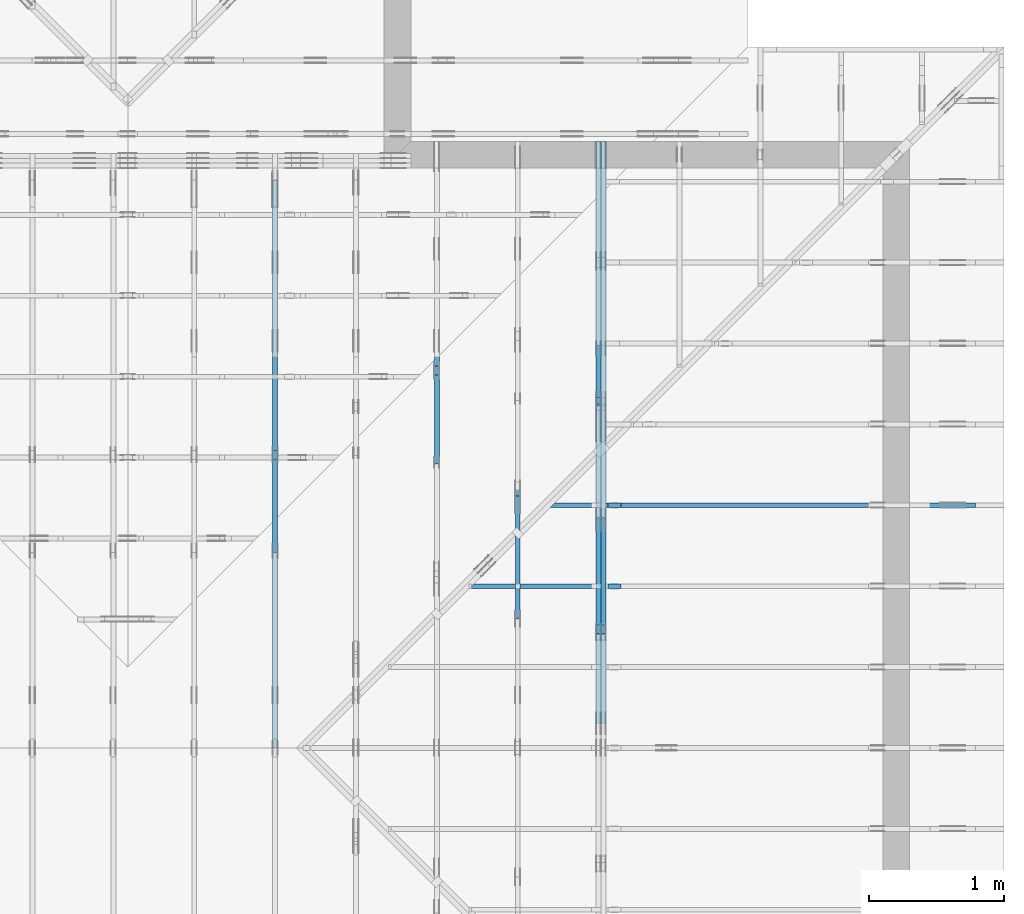
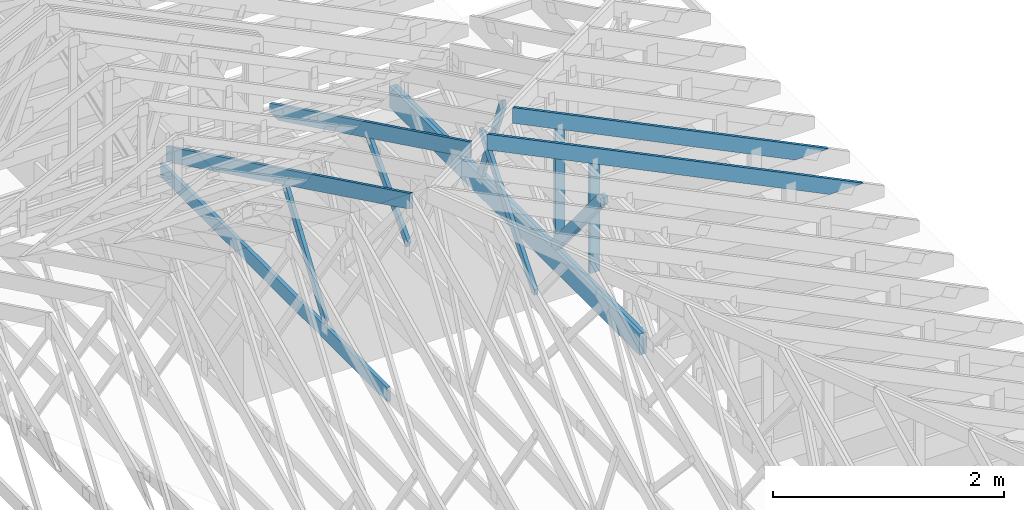
# One storey, part 34 of 159: 15 members, 6 elements without a shape of their own.
"""IFC2X3 building model written with IfcOpenShell, lengths in millimetres."""

from ifc_helpers import new_model, si_unit, frame, origin, origin_with_axes, origin_2d, place, context, project, spatial, faceted_brep, element, aggregate, save


model = new_model("IFC2X3")

# Units and contexts
model_context = context("Model", 3, precision=1e-05, world=origin())
plan_context = context("Plan", 2, precision=1e-05, world=origin_2d())
ifc_project = project(units=[si_unit("LENGTHUNIT", "METRE", prefix="MILLI"), si_unit("AREAUNIT", "SQUARE_METRE"), si_unit("VOLUMEUNIT", "CUBIC_METRE"), si_unit("SOLIDANGLEUNIT", "STERADIAN"), si_unit("PLANEANGLEUNIT", "RADIAN"), si_unit("MASSUNIT", "GRAM"), si_unit("TIMEUNIT", "SECOND"), si_unit("THERMODYNAMICTEMPERATUREUNIT", "DEGREE_CELSIUS"), si_unit("LUMINOUSINTENSITYUNIT", "LUMEN")], contexts=[model_context, plan_context])

# Site, building, storey
site_placement = place(None, origin_with_axes())
site = spatial("IfcSite", under=ifc_project, at=site_placement, CompositionType="ELEMENT")
building_placement = place(site_placement, origin_with_axes())
building = spatial("IfcBuilding", under=site, at=building_placement, Name="Plan 1", CompositionType="ELEMENT")
storey_placement = place(building_placement, origin_with_axes())
storey = spatial("IfcBuildingStorey", under=building, at=storey_placement, Name="Etasje 1", CompositionType="ELEMENT", Elevation=0.0)

# Assembly, members
assembly_1_placement = place(storey_placement, frame((18074.541652722903, -699.9989301294845, 4.408582873760558e-15), z_axis=(-1.0, 1.836909530733566e-16, 6.123031769111886e-17), x_axis=(-1.836909530733566e-16, -1.0, 0.0)))
assembly_1 = element("IfcElementAssembly", 1, at=assembly_1_placement, inside=storey, Name="V5 (30)", AssemblyPlace="FACTORY", PredefinedType="TRUSS")
member_1_placement = place(assembly_1_placement, frame((-5380.0, 223.0, -36.0), z_axis=(0.0, 0.0, 1.0), x_axis=(-1.0, 1.2246063538223773e-16, 0.0)))
member_1 = element("IfcMember", 2, at=member_1_placement, Name="V5-U8", context=model_context, shape_type="Brep", body=[
    faceted_brep([(4319.9990234375, 223.00000000000054, 36.0), (0.0, 223.00000000000054, 36.0), (0.0, 0.0, 36.0), (4319.9990234375, 0.0, 36.0), (0.0, 223.00000000000054, 0.0), (4319.9990234375, 223.00000000000054, 5.290298252608027e-13), (4319.9990234375, 0.0, 5.290298252608027e-13), (0.0, 0.0, 0.0), (7.657189310092548e-29, 6.252776074688882e-13, -4.68852134078006e-45), (2.2042914368803556e-15, 6.252776074688882e-13, 36.0), (2.951301312711937e-14, 223.00000000000063, 36.0), (2.730872169023909e-14, 223.00000000000063, -1.6721217048316878e-30), (4319.998923973448, -1.6826711215166942e-13, 4.3368184391231664e-29), (4319.998923973448, -1.6606282071478914e-13, 36.0), (4.049083948919771e-31, 6.274818989057684e-13, 36.0), (0.0, 6.252776074688882e-13, 0.0), (4319.998923973448, 223.00000000000054, 0.0), (4319.998923973448, 223.00000000000054, 36.0), (4319.998923973448, 5.400124791776761e-13, 36.0), (4319.998923973448, 5.400124791776761e-13, 0.0), (0.0, 223.00000000000063, 0.0), (0.0, 223.00000000000063, 36.0), (4319.998923973448, 223.00000000000037, 36.0), (4319.998923973448, 223.00000000000037, -1.1044052673094165e-29)], [[[0, 1, 2, 3]], [[4, 5, 6, 7]], [[8, 9, 10, 11]], [[12, 13, 14, 15]], [[16, 17, 18, 19]], [[20, 21, 22, 23]]]),
])
member_2_placement = place(assembly_1_placement, frame((-5380.0, 223.0, -72.0), z_axis=(0.0, 0.0, 1.0), x_axis=(-1.0, 1.2246063538223773e-16, 0.0)))
member_2 = element("IfcMember", 3, at=member_2_placement, Name="V5-U8", context=model_context, shape_type="Brep", body=[
    faceted_brep([(4319.9990234375, 223.00000000000054, 36.0), (0.0, 223.00000000000054, 36.0), (0.0, 0.0, 36.0), (4319.9990234375, 0.0, 36.0), (0.0, 223.00000000000054, 0.0), (4319.9990234375, 223.00000000000054, 5.290298252608027e-13), (4319.9990234375, 0.0, 5.290298252608027e-13), (0.0, 0.0, 0.0), (7.657189310092548e-29, 6.252776074688882e-13, -4.68852134078006e-45), (2.2042914368803556e-15, 6.252776074688882e-13, 36.0), (2.951301312711937e-14, 223.00000000000063, 36.0), (2.730872169023909e-14, 223.00000000000063, -1.6721217048316878e-30), (4319.998923973448, -1.6826711215166942e-13, 4.3368184391231664e-29), (4319.998923973448, -1.6606282071478914e-13, 36.0), (4.049083948919771e-31, 6.274818989057684e-13, 36.0), (0.0, 6.252776074688882e-13, 0.0), (4319.998923973448, 223.00000000000054, 0.0), (4319.998923973448, 223.00000000000054, 36.0), (4319.998923973448, 5.400124791776761e-13, 36.0), (4319.998923973448, 5.400124791776761e-13, 0.0), (0.0, 223.00000000000063, 0.0), (0.0, 223.00000000000063, 36.0), (4319.998923973448, 223.00000000000037, 36.0), (4319.998923973448, 223.00000000000037, -1.1044052673094165e-29)], [[[0, 1, 2, 3]], [[4, 5, 6, 7]], [[8, 9, 10, 11]], [[12, 13, 14, 15]], [[16, 17, 18, 19]], [[20, 21, 22, 23]]]),
])
member_3_placement = place(assembly_1_placement, frame((-7784.008629309485, 1261.0239014078534, -35.99999999999999), z_axis=(0.0, 0.0, 1.0), x_axis=(-0.3612308951582944, -0.9324764020516215, 0.0)))
member_3 = element("IfcMember", 4, at=member_3_placement, Name="V5-D49", context=model_context, shape_type="Brep", body=[
    faceted_brep([(1084.9109850654727, 73.000426766278, 36.0), (62.15332242535737, 73.000426766278, 36.0), (6.463713430093776e-05, 36.500128102201415, 36.0), (39.3830811553712, 0.0001626723005756503, 36.0), (1113.1905312820863, 0.0001626723005756503, 36.0), (62.15332242535737, 73.000426766278, 7.611335355326349e-15), (1084.9109850654727, 73.000426766278, 1.328588885642872e-13), (1113.1905312820863, 0.0001626723005756503, 1.3632201976229506e-13), (39.3830811553712, 0.0001626723005756503, 4.82287714159699e-15), (6.463713430093776e-05, 36.500128102201415, 7.91550453577987e-21), (3.552713678800501e-15, 36.500210312128736, 0.0), (5.329070518200751e-15, 36.500210312128736, 36.0), (62.15334871027269, 73.00021031312829, 36.0), (62.15334871027269, 73.00021031312829, 7.888609052210118e-31), (39.38304675078666, 0.00021031312735075858, 1.9721522630525295e-31), (39.38304675078666, 0.00021031312735075858, 36.0), (7.105427357601002e-15, 36.50021031212874, 36.0), (7.105427357601002e-15, 36.50021031212874, -5.9164567891575885e-31), (1113.1904498091412, 0.00021031312619447325, 1.532860281653061e-29), (1113.1904498091412, 0.00021031312619667754, 36.0), (39.38304675078666, 0.0002103131273476588, 36.0), (39.38304675078666, 0.0002103131273454545, 5.423042565202193e-31), (1084.9110689169952, 73.00021031312644, 9.978856970719965e-31), (1084.9110689169952, 73.00021031312644, 36.0), (1113.1904498091412, 0.0002103131264448166, 36.0), (1113.1904498091412, 0.0002103131264448166, 1.2391235632630343e-30), (62.15334871027267, 73.00021031312826, 0.0), (62.15334871027267, 73.00021031312826, 36.0), (1084.9110689169952, 73.00021031312639, 36.0), (1084.9110689169952, 73.00021031312639, -3.944304526105059e-30)], [[[0, 1, 2, 3, 4]], [[5, 6, 7, 8, 9]], [[10, 11, 12, 13]], [[14, 15, 16, 17]], [[18, 19, 20, 21]], [[22, 23, 24, 25]], [[26, 27, 28, 29]]]),
])
member_4_placement = place(assembly_1_placement, frame((-6087.706549484205, 1279.1200830192452, -36.0), z_axis=(0.0, 0.0, 1.0), x_axis=(-0.6383914022223945, -0.7697119055650139, 0.0)))
member_4 = element("IfcMember", 5, at=member_4_placement, Name="V5-D8", context=model_context, shape_type="Brep", body=[
    faceted_brep([(1290.817726644516, 97.99992714313066, 36.0), (46.360171039623765, 97.99992714313066, 36.0), (6.467156754297321e-05, 48.9999801757549, 36.0), (40.64016108570149, 0.0, 36.0), (1285.0974284657855, 0.0, 36.0), (1331.4578230586499, 48.9999801757549, 36.0), (46.360171039623765, 97.99992714313066, 5.677296001941543e-15), (1290.817726644516, 97.99992714313066, 1.5807435896754306e-13), (1331.4578230586499, 48.9999801757549, 1.6305117099641332e-13), (1285.0974284657855, 0.0, 1.5737384761799988e-13), (40.64016108570149, 0.0, 4.976819948591497e-15), (6.467156754297321e-05, 48.9999801757549, 7.919721252477802e-21), (-3.552713678800501e-15, 49.000010255495916, 7.888609052210118e-31), (-3.552713678800501e-15, 49.000010255495916, 36.0), (46.360214275270664, 98.00001025548592, 36.0), (46.360214275270664, 98.00001025548592, 1.1832913578315177e-30), (40.640112856158794, 1.0255486813548487e-05, 3.944304526105059e-31), (40.640112856158794, 1.0255486813548487e-05, 36.0), (7.105427357601002e-15, 49.000010255495916, 36.0), (7.105427357601002e-15, 49.000010255495916, -3.944304526105059e-31), (1285.0975562928038, 1.02554843540984e-05, 3.921561117829078e-29), (1285.0975562928038, 1.0255484356302691e-05, 36.0), (40.640112856158794, 1.0255486795498755e-05, 36.0), (40.640112856158794, 1.0255486793294464e-05, 1.240160269891531e-30), (1331.4577705681208, 49.00001025548693, -1.9384631865713643e-29), (1331.4577705681208, 49.00001025548693, 36.0), (1285.0975562928038, 1.0255485108245921e-05, 36.0), (1285.0975562928038, 1.0255485108245921e-05, -7.178585139208741e-30), (1290.817657711957, 98.00001025548306, 0.0), (1290.817657711957, 98.00001025548306, 36.0), (1331.4577705681208, 49.0000102554867, 36.0), (1331.4577705681208, 49.0000102554867, 0.0), (46.360214275270664, 98.0000102554859, 0.0), (46.360214275270664, 98.00001025548589, 36.0), (1290.817657711957, 98.00001025548306, 36.0), (1290.817657711957, 98.00001025548306, -7.888609052210118e-30)], [[[0, 1, 2, 3, 4, 5]], [[6, 7, 8, 9, 10, 11]], [[12, 13, 14, 15]], [[16, 17, 18, 19]], [[20, 21, 22, 23]], [[24, 25, 26, 27]], [[28, 29, 30, 31]], [[32, 33, 34, 35]]]),
])
member_5_placement = place(assembly_1_placement, frame((-6087.706549484205, 1279.1200830192452, -72.0), z_axis=(0.0, 0.0, 1.0), x_axis=(-0.6383914022223945, -0.7697119055650139, 0.0)))
member_5 = element("IfcMember", 6, at=member_5_placement, Name="V5-D8", context=model_context, shape_type="Brep", body=[
    faceted_brep([(1290.817726644516, 97.99992714313066, 36.0), (46.360171039623765, 97.99992714313066, 36.0), (6.467156754297321e-05, 48.9999801757549, 36.0), (40.64016108570149, 0.0, 36.0), (1285.0974284657855, 0.0, 36.0), (1331.4578230586499, 48.9999801757549, 36.0), (46.360171039623765, 97.99992714313066, 5.677296001941543e-15), (1290.817726644516, 97.99992714313066, 1.5807435896754306e-13), (1331.4578230586499, 48.9999801757549, 1.6305117099641332e-13), (1285.0974284657855, 0.0, 1.5737384761799988e-13), (40.64016108570149, 0.0, 4.976819948591497e-15), (6.467156754297321e-05, 48.9999801757549, 7.919721252477802e-21), (-3.552713678800501e-15, 49.000010255495916, 7.888609052210118e-31), (-3.552713678800501e-15, 49.000010255495916, 36.0), (46.360214275270664, 98.00001025548592, 36.0), (46.360214275270664, 98.00001025548592, 1.1832913578315177e-30), (40.640112856158794, 1.0255486813548487e-05, 3.944304526105059e-31), (40.640112856158794, 1.0255486813548487e-05, 36.0), (7.105427357601002e-15, 49.000010255495916, 36.0), (7.105427357601002e-15, 49.000010255495916, -3.944304526105059e-31), (1285.0975562928038, 1.02554843540984e-05, 3.921561117829078e-29), (1285.0975562928038, 1.0255484356302691e-05, 36.0), (40.640112856158794, 1.0255486795498755e-05, 36.0), (40.640112856158794, 1.0255486793294464e-05, 1.240160269891531e-30), (1331.4577705681208, 49.00001025548693, -1.9384631865713643e-29), (1331.4577705681208, 49.00001025548693, 36.0), (1285.0975562928038, 1.0255485108245921e-05, 36.0), (1285.0975562928038, 1.0255485108245921e-05, -7.178585139208741e-30), (1290.817657711957, 98.00001025548306, 0.0), (1290.817657711957, 98.00001025548306, 36.0), (1331.4577705681208, 49.0000102554867, 36.0), (1331.4577705681208, 49.0000102554867, 0.0), (46.360214275270664, 98.0000102554859, 0.0), (46.360214275270664, 98.00001025548589, 36.0), (1290.817657711957, 98.00001025548306, 36.0), (1290.817657711957, 98.00001025548306, -7.888609052210118e-30)], [[[0, 1, 2, 3, 4, 5]], [[6, 7, 8, 9, 10, 11]], [[12, 13, 14, 15]], [[16, 17, 18, 19]], [[20, 21, 22, 23]], [[24, 25, 26, 27]], [[28, 29, 30, 31]], [[32, 33, 34, 35]]]),
])
aggregate(assembly_1, [member_1, member_2, member_3, member_4, member_5])

# Assembly, member
assembly_2_placement = place(storey_placement, frame((17475.02226140475, -699.9989301294827, 1.1021457184401395e-15), z_axis=(-1.0, 1.836909530733566e-16, 6.123031769111886e-17), x_axis=(-1.836909530733566e-16, -1.0, 0.0)))
assembly_2 = element("IfcElementAssembly", 7, at=assembly_2_placement, inside=storey, Name="V6 (31)", AssemblyPlace="FACTORY", PredefinedType="TRUSS")
member_6_placement = place(assembly_2_placement, frame((-7142.86420088834, 1534.8876563125746, -36.0), z_axis=(0.0, 0.0, 1.0), x_axis=(0.6278034094765356, -0.7783719413298744, 0.0)))
member_6 = element("IfcMember", 8, at=member_6_placement, Name="V6-D29", context=model_context, shape_type="Brep", body=[
    faceted_brep([(1479.4702259563355, 73.00004444771184, 36.0), (29.43962697065308, 73.00004444771184, 36.0), (0.0, 36.500015093747606, 36.0), (54.103324634555975, 0.0, 36.0), (1495.2848439964773, 0.0, 36.0), (1524.7241644224969, 36.500015093747606, 36.0), (29.43962697065308, 73.00004444771184, 3.605195424242239e-15), (1479.4702259563355, 73.00004444771184, 1.8117686389971566e-13), (1524.7241644224969, 36.500015093747606, 1.8671868995783048e-13), (1495.2848439964773, 0.0, 1.8311353207323884e-13), (54.103324634555975, 0.0, 6.6255275110391995e-15), (0.0, 36.500015093747606, 0.0), (7.181687850987828e-05, 36.50010657639906, 5.695249338425663e-31), (7.181687850987828e-05, 36.50010657639906, 36.0), (29.439499459812385, 73.00010657668193, 36.0), (29.439499459812385, 73.00010657668193, 1.252954264189902e-30), (54.10347952602115, 0.00010657668189040237, 3.944304526105059e-31), (54.10347952602115, 0.00010657668189395508, 36.0), (7.18168785169837e-05, 36.50010657639905, 36.0), (7.18168785169837e-05, 36.50010657639905, 0.0), (1495.284787929586, 0.00010657668414597599, 8.529771067080819e-29), (1495.284787929586, 0.00010657668414818028, 36.0), (54.10347952602115, 0.00010657668185285997, 36.0), (54.10347952602115, 0.00010657668185065568, 3.0863042405133145e-30), (1524.7242155722893, 36.50010657668304, -3.131801040387511e-29), (1524.7242155722893, 36.50010657668304, 36.0), (1495.2847879295855, 0.00010657668576641299, 36.0), (1495.2847879295855, 0.00010657668576641299, -1.8407237042604356e-29), (1479.470278703382, 73.00010657668463, 0.0), (1479.470278703382, 73.00010657668463, 36.0), (1524.7242155722897, 36.50010657668281, 36.0), (1524.7242155722897, 36.50010657668281, 0.0), (29.439499459812396, 73.0001065766819, 0.0), (29.439499459812396, 73.0001065766819, 36.0), (1479.470278703382, 73.00010657668471, 36.0), (1479.470278703382, 73.00010657668471, 4.733165431326071e-30)], [[[0, 1, 2, 3, 4, 5]], [[6, 7, 8, 9, 10, 11]], [[12, 13, 14, 15]], [[16, 17, 18, 19]], [[20, 21, 22, 23]], [[24, 25, 26, 27]], [[28, 29, 30, 31]], [[32, 33, 34, 35]]]),
])
aggregate(assembly_2, [member_6])

# Assembly, members
assembly_3_placement = place(storey_placement, frame((16875.02226140475, -699.9989301294827, 1.1021457184401395e-15), z_axis=(-1.0, 1.836909530733566e-16, 6.123031769111886e-17), x_axis=(-1.836909530733566e-16, -1.0, 0.0)))
assembly_3 = element("IfcElementAssembly", 9, at=assembly_3_placement, inside=storey, Name="V7 (32)", AssemblyPlace="FACTORY", PredefinedType="TRUSS")
member_7_placement = place(assembly_3_placement, frame((-9670.743130822755, 311.0167315311314, -36.00000021309109), z_axis=(0.0, 0.0, 1.0), x_axis=(0.8987940462991671, 0.4383711467890771, 0.0)))
member_7 = element("IfcMember", 10, at=member_7_placement, Name="V7-O24", context=model_context, shape_type="Brep", body=[
    faceted_brep([(3904.9010828301844, 147.99999481553152, 36.00000325139126), (3832.716658871803, 2.3862867237767205e-09, 36.00000021309188), (3792.6629889252335, 3.2948491934803315e-07, 6.821210263296962e-13), (3864.847412883614, 147.99999514263084, 3.038298928004224e-06), (39.634480415881626, 147.99999999999, 2.1309109143885507e-07), (39.634480415881626, 147.99999999999, 36.00000021309109), (3904.9010819783834, 147.99999999998977, 36.00000021309109), (3864.8474130025534, 147.99999999998977, 2.1309109143885507e-07), (39.63427734374818, 148.00000000097862, 2.1309109629249386e-07), (3864.847412109374, 148.00000000097862, 2.130915647305248e-07), (3792.662986755371, 0.0, 2.1309155589077422e-07), (136.83227539062318, 0.0, 2.1309110819542245e-07), (0.0, 66.73750305175781, 2.1309109143885507e-07), (1.3711214528200344e-06, 66.7374999422282, 9.832911800344844e-07), (1.37112253995042e-06, 66.73749994222766, 36.00000021309109), (39.6343697170541, 147.99999762046178, 36.00000003017288), (39.63436971705302, 147.99999762046232, 2.917114876765936e-06), (136.83215445954372, 9.130403100243711e-10, 2.1309109143885507e-07), (136.83215445954372, 9.130403100243711e-10, 36.00000021309109), (4.4894022863672944e-06, 66.73749870488248, 36.00000021309109), (4.4894022863672944e-06, 66.73749870488248, 2.1309109143885507e-07), (3832.7166579786126, 2.369483396342992e-09, 36.00000021309109), (136.83217845590843, 2.3701622968854846e-09, 36.00000021309109), (136.83217845590843, 2.3701520989882704e-09, 2.1309109143885507e-07), (3792.6629890027825, 2.369480555942406e-09, 2.1309109143885507e-07), (3904.9010842258076, 148.0000000023856, 36.00000021309109), (39.63438348117961, 148.0000000023856, 36.00000021309109), (0.00010613742961140815, 66.73750305414251, 36.00000021309109), (136.8321373874278, 9.12223185878247e-10, 36.00000021309109), (3832.7166588718037, 9.12223185878247e-10, 36.00000021309109)], [[[0, 1, 2, 3]], [[4, 5, 6, 7]], [[8, 9, 10, 11, 12]], [[13, 14, 15, 16]], [[17, 18, 19, 20]], [[21, 22, 23, 24]], [[25, 26, 27, 28, 29]]]),
])
member_8_placement = place(assembly_3_placement, frame((-8034.738498491773, 1108.9494935142695, -36.00000000000001), z_axis=(0.0, 0.0, 1.0), x_axis=(0.6848977524081675, -0.7286391896859794, 0.0)))
member_8 = element("IfcMember", 11, at=member_8_placement, Name="V7-D51", context=model_context, shape_type="Brep", body=[
    faceted_brep([(987.9089683124994, 73.0000731772916, 36.0), (22.63590702906731, 73.0000731772916, 36.0), (0.00017110198859882075, 0.00013731680337514263, 36.0), (1012.7776599997351, 0.00013731680337514263, 36.0), (22.63590702906731, 73.0000731772916, 2.7720075572328443e-15), (987.9089683124994, 73.0000731772916, 1.2097995995935964e-13), (1012.7776599997351, 0.00013731680337514263, 1.2402539574450348e-13), (0.00017110198859882075, 0.00013731680337514263, 2.0953258238975985e-20), (2.0298365310637834e-15, 3.7179159334580575e-05, -1.3012553192416204e-31), (4.135235177286228e-15, 3.7179159333927736e-05, 36.0), (22.63576821184871, 73.00003717915934, 36.0), (22.635768211848706, 73.00003717915934, -4.057934392823906e-31), (1012.7776949466388, 3.717916004869918e-05, 1.2001479468223093e-29), (1012.7776949466388, 3.717916005090347e-05, 36.0), (-1.5528953697526569e-30, 3.717915933741428e-05, 36.0), (0.0, 3.717915933520999e-05, 0.0), (987.9089334679858, 73.00003717915934, 1.262177448353619e-29), (987.9089334679858, 73.00003717915934, 36.0), (1012.7776949466389, 3.717916030154811e-05, 36.0), (1012.7776949466389, 3.717916030154811e-05, 0.0), (22.6357682118487, 73.00003717915934, 0.0), (22.6357682118487, 73.00003717915934, 36.0), (987.9089334679857, 73.00003717915928, 36.0), (987.9089334679857, 73.00003717915928, -3.944304526105059e-30)], [[[0, 1, 2, 3]], [[4, 5, 6, 7]], [[8, 9, 10, 11]], [[12, 13, 14, 15]], [[16, 17, 18, 19]], [[20, 21, 22, 23]]]),
])
aggregate(assembly_3, [member_7, member_8])

assembly_4_placement = place(storey_placement, frame((21100.012663101486, 5717.993668449257, 1.1021457184401395e-15), z_axis=(1.2246063538223773e-16, 1.0, 6.123031769111886e-17), x_axis=(-1.0, 1.2246063538223773e-16, 0.0)))
assembly_4 = element("IfcElementAssembly", 12, at=assembly_4_placement, inside=storey, Name="S15 (47)", AssemblyPlace="FACTORY", PredefinedType="TRUSS")
member_9_placement = place(assembly_4_placement, frame((276.06022270963166, 89.97847947456873, -36.000000217534904), z_axis=(0.0, 0.0, 1.0), x_axis=(0.8987940462991673, 0.43837114678907696, 0.0)))
member_9 = element("IfcMember", 13, at=member_9_placement, Name="S15-O20", context=model_context, shape_type="Brep", body=[
    faceted_brep([(4178.836479963479, 148.000000830786, 2.2532879029313335e-06), (4138.782812966098, 147.99999513790726, 35.999997187282816), (4066.5983890149373, 3.212395540685975e-07, 36.00000021753476), (4106.652058957514, 0.0, 0.0), (9.727858389396715e-05, 148.00000032051958, 2.1753489676257232e-07), (9.727858389396715e-05, 148.00000032051958, 36.0000002175349), (4138.782812122334, 148.00000032051932, 36.0000002175349), (4178.836481098164, 148.00000032051932, 2.1753489676257232e-07), (303.4449717131315, 3.206154843837794e-07, 2.1753489676257232e-07), (303.4449717131315, 3.206154843837794e-07, 36.0000002175349), (0.0, 148.00000186155552, 36.0000002175349), (0.0, 148.00000186155552, 2.1753489676257232e-07), (4106.65205887215, 3.2124596198454335e-07, 2.1753489676257232e-07), (4066.5983898963204, 3.212459715463314e-07, 36.0000002175349), (303.4450276221495, 3.212466628035591e-07, 36.0000002175349), (303.4450276221495, 3.2124666059926766e-07, 2.1753489676257232e-07), (4138.782814368941, 148.00000032124012, 36.0000002175349), (3.430621973166126e-07, 148.00000032124012, 36.0000002175349), (303.44506870243765, 3.2061552701634355e-07, 36.0000002175349), (4066.5983890149373, 3.2061552701634355e-07, 36.0000002175349), (5.619829477154781e-05, 148.00000031994657, 2.175348967625792e-07), (4178.836481979545, 148.00000031994657, 2.1753540850554306e-07), (4106.652056625541, 3.205252596671926e-07, 2.1753539966579247e-07), (303.4448804170448, 3.205252596671926e-07, 2.1753493392262518e-07)], [[[0, 1, 2, 3]], [[4, 5, 6, 7]], [[8, 9, 10, 11]], [[12, 13, 14, 15]], [[16, 17, 18, 19]], [[20, 21, 22, 23]]]),
])
member_10_placement = place(assembly_4_placement, frame((2840.990401698568, 1388.7763671875, -36.0), z_axis=(0.0, 0.0, 1.0), x_axis=(-1.836909530733566e-16, -1.0, 0.0)))
member_10 = element("IfcMember", 14, at=member_10_placement, Name="S15-S8", context=model_context, shape_type="Brep", body=[
    faceted_brep([(1165.7763671875, 98.00007681705756, 36.0), (0.0, 98.00007681705756, 36.0), (47.7978515625, 7.681705710638198e-05, 36.0), (1165.7763671875, 7.681705710638198e-05, 36.0), (0.0, 98.00007681705756, 0.0), (1165.7763671875, 98.00007681705756, 1.4276171463937812e-13), (1165.7763671875, 7.681705710638198e-05, 1.4276171463937812e-13), (47.7978515625, 7.681705710638198e-05, 5.853355272249634e-15), (47.79785166681542, 1.4100720591159188e-11, -1.247858387398912e-30), (47.79785166681542, 1.4100720591159188e-11, 36.0), (5.7987337655163174e-05, 98.0000000000141, 36.0), (5.7987337655163174e-05, 98.0000000000141, -1.306298835932967e-30), (1165.776367187592, -1.0110684919648689e-14, 6.190804497048674e-31), (1165.776367187592, -7.90639348276841e-15, 36.0), (47.797851666815404, 1.4098957621983875e-11, 36.0), (47.797851666815404, 1.4096753330546995e-11, 2.5382840429444347e-32), (1165.776367187592, 97.99999999998545, 3.736045247126712e-27), (1165.776367187592, 97.99999999998545, 36.0), (1165.776367187592, 0.0, 36.0), (1165.776367187592, 0.0, 0.0), (5.798733764095232e-05, 98.0000000000141, 0.0), (5.798733764095232e-05, 98.0000000000141, 36.0), (1165.7763671875312, 97.99999999998555, 36.0), (1165.7763671875312, 97.99999999998555, 6.310887241768095e-30)], [[[0, 1, 2, 3]], [[4, 5, 6, 7]], [[8, 9, 10, 11]], [[12, 13, 14, 15]], [[16, 17, 18, 19]], [[20, 21, 22, 23]]]),
])
aggregate(assembly_4, [member_9, member_10])

assembly_5_placement = place(storey_placement, frame((21100.012663101486, 6317.993668449257, 1.1021457184401395e-15), z_axis=(1.2246063538223773e-16, 1.0, 6.123031769111886e-17), x_axis=(-1.0, 1.2246063538223773e-16, 0.0)))
assembly_5 = element("IfcElementAssembly", 15, at=assembly_5_placement, inside=storey, Name="S16 (45)", AssemblyPlace="FACTORY", PredefinedType="TRUSS")
member_11_placement = place(assembly_5_placement, frame((276.06015716079526, 89.97844750295032, -36.00000021753527), z_axis=(0.0, 0.0, 1.0), x_axis=(0.8987940462991673, 0.43837114678907685, 0.0)))
member_11 = element("IfcMember", 16, at=member_11_placement, Name="S16-O30", context=model_context, shape_type="Brep", body=[
    faceted_brep([(3511.2753886081327, 148.0000008307835, 2.2532910861627897e-06), (3471.221721610752, 147.99999513790556, 35.99999718728668), (3399.037297659588, 3.212395540685975e-07, 36.00000021753567), (3439.090967602164, -2.2737367544323206e-13, 4.547473508864641e-13), (4.10802904866614e-05, 148.00000032217343, 2.1753527335022227e-07), (4.10802904866614e-05, 148.0000003221732, 36.00000021753527), (3471.2217207677904, 148.000000322173, 36.00000021753527), (3511.2753897436205, 148.0000003221732, 2.1753527335022227e-07), (303.4450446434703, 3.2179700326651073e-07, 2.1753527335022227e-07), (303.4450446434703, 3.2179700326651073e-07, 36.00000021753527), (7.293033898037038e-05, 148.00000186273726, 36.00000021753527), (7.293033898037038e-05, 148.00000186273726, 2.1753527335022227e-07), (3439.090967516788, 3.2123214330237585e-07, 2.175352733502223e-07), (3399.0372985409576, 3.212321528641639e-07, 36.00000021753527), (303.44497142303766, 3.212327214964688e-07, 36.00000021753527), (303.44497142303766, 3.212327192921774e-07, 2.175352733502223e-07), (3471.221723013591, 148.00000032124012, 36.00000021753527), (0.00018828458706821039, 148.00000032124012, 36.00000021753527), (303.4450125033372, 3.2179710274249373e-07, 36.00000021753527), (3399.0372976595872, 3.2179710274249373e-07, 36.00000021753527), (0.0, 148.00000032112854, 2.1753527335022227e-07), (3511.275390625, 148.00000032112854, 2.175357033432376e-07), (3439.090965270996, 3.221853148716036e-07, 2.1753569450348702e-07), (303.44506835937483, 3.221853148716036e-07, 2.1753531051029813e-07)], [[[0, 1, 2, 3]], [[4, 5, 6, 7]], [[8, 9, 10, 11]], [[12, 13, 14, 15]], [[16, 17, 18, 19]], [[20, 21, 22, 23]]]),
])
member_12_placement = place(assembly_5_placement, frame((2840.990401698568, 1388.7763671875, -36.0), z_axis=(0.0, 0.0, 1.0), x_axis=(-1.836909530733566e-16, -1.0, 0.0)))
member_12 = element("IfcMember", 17, at=member_12_placement, Name="S16-S8", context=model_context, shape_type="Brep", body=[
    faceted_brep([(1165.7763671875, 98.00007681705756, 36.0), (0.0, 98.00007681705756, 36.0), (47.7978515625, 7.681705710638198e-05, 36.0), (1165.7763671875, 7.681705710638198e-05, 36.0), (0.0, 98.00007681705756, 0.0), (1165.7763671875, 98.00007681705756, 1.4276171463937812e-13), (1165.7763671875, 7.681705710638198e-05, 1.4276171463937812e-13), (47.7978515625, 7.681705710638198e-05, 5.853355272249634e-15), (47.79785166781221, 1.4090062450122787e-11, 3.944304526105059e-31), (47.79785166781221, 1.4090062450122787e-11, 36.0), (5.7988370848249815e-05, 98.00000000001414, 36.0), (5.7988370848249815e-05, 98.00000000001414, -1.9721522630525295e-30), (1165.776367187592, -1.0110684906543046e-14, 6.19080448902383e-31), (1165.776367187592, -7.906393469662767e-15, 36.0), (47.79785166781221, 1.4098957621984403e-11, 36.0), (47.79785166781221, 1.4096753330547523e-11, 2.538284039715843e-32), (1165.776367187592, 97.99999999998545, 3.736045247126712e-27), (1165.776367187592, 97.99999999998545, 36.0), (1165.776367187592, 0.0, 36.0), (1165.776367187592, 0.0, 0.0), (5.798837082693353e-05, 98.0000000000141, 0.0), (5.798837082693353e-05, 98.0000000000141, 36.0), (1165.7763671875312, 97.99999999998555, 36.0), (1165.7763671875312, 97.99999999998555, 6.310887241768095e-30)], [[[0, 1, 2, 3]], [[4, 5, 6, 7]], [[8, 9, 10, 11]], [[12, 13, 14, 15]], [[16, 17, 18, 19]], [[20, 21, 22, 23]]]),
])
aggregate(assembly_5, [member_11, member_12])

assembly_6_placement = place(storey_placement, frame((15675.02226140475, -699.9989301294845, 1.1021457184401395e-15), z_axis=(-1.0, 1.836909530733566e-16, 6.123031769111886e-17), x_axis=(-1.836909530733566e-16, -1.0, 0.0)))
assembly_6 = element("IfcElementAssembly", 18, at=assembly_6_placement, inside=storey, Name="T7 (111)", AssemblyPlace="FACTORY", PredefinedType="TRUSS")
member_13_placement = place(assembly_6_placement, frame((-9411.999005287185, 437.2146234308699, -36.00000000000001), z_axis=(0.0, 0.0, 1.0), x_axis=(0.8987940462991673, 0.43837114678907735, 0.0)))
member_13 = element("IfcMember", 19, at=member_13_placement, Name="T7-O11", context=model_context, shape_type="Brep", body=[
    faceted_brep([(4758.463277584195, 148.00009154954296, 36.0), (72.18442876594781, 148.00009154954296, 36.0), (0.0, 4.140399232710479e-05, 36.0), (4686.278875574299, 4.140399232710479e-05, 36.0), (72.18442876594781, 148.00009154954296, 8.839751011381847e-15), (4758.463277584195, 148.00009154954296, 5.82724436416006e-13), (4686.278875574299, 4.140399232710479e-05, 5.738846886811872e-13), (0.0, 4.140399232710479e-05, 0.0), (8.360351420234293e-05, 5.140324472498181e-15, 7.179836740020234e-31), (8.360351420432413e-05, 4.174029286270475e-15, 36.0), (72.18450667705471, 147.99999999603824, 36.0), (72.18450667705471, 147.99999999603824, 1.530729119798975e-30), (4686.27888374885, 4.514103814251943e-05, -1.8242490005659002e-29), (4686.27888374885, 4.514103814472372e-05, 36.0), (8.360351421288216e-05, 2.204296752011599e-15, 36.0), (8.360351421288216e-05, 5.315131319929112e-21, -3.254471682622608e-37), (4758.463306857064, 148.00004514198963, 1.58299098763632e-28), (4758.463306857064, 148.00004514198963, 36.0), (4686.2788837488515, 4.5141036935092416e-05, 36.0), (4686.2788837488515, 4.5141036935092416e-05, 1.0730458735393999e-28), (72.18450667705474, 147.99999999603824, 0.0), (72.18450667705474, 147.99999999603824, 36.0), (4758.463306857063, 148.00004514199048, 36.0), (4758.463306857063, 148.00004514199048, -2.8398992587956425e-29)], [[[0, 1, 2, 3]], [[4, 5, 6, 7]], [[8, 9, 10, 11]], [[12, 13, 14, 15]], [[16, 17, 18, 19]], [[20, 21, 22, 23]]]),
])
member_14_placement = place(assembly_6_placement, frame((-5591.18115234375, 371.0, -36.0), z_axis=(0.0, 0.0, 1.0), x_axis=(-1.0, 1.2246063538223773e-16, 0.0)))
member_14 = element("IfcMember", 20, at=member_14_placement, Name="T7-U39", context=model_context, shape_type="Brep", body=[
    faceted_brep([(3910.81787109375, 148.00000000000048, 36.0), (0.0, 148.00000000000048, 36.0), (0.0, 0.0, 36.0), (3910.81787109375, 0.0, 36.0), (0.0, 148.00000000000048, 0.0), (3910.81787109375, 148.00000000000048, 4.789212413583509e-13), (3910.81787109375, 0.0, 4.789212413583509e-13), (0.0, 0.0, 0.0), (0.0001433398574590683, 3.979039320256561e-13, 0.0), (0.0001433398574612726, 3.979039320256561e-13, 36.0), (0.00014333985747939676, 148.00000000000037, 36.0), (0.00014333985747719247, 148.00000000000037, -1.1097494219785373e-30), (3910.817777776101, -3.204779149536956e-13, 4.746728930957506e-29), (3910.817777776101, -3.182736235168153e-13, 36.0), (0.0001433398574590683, 4.001081950488681e-13, 36.0), (0.0001433398574590683, 3.9790390361198783e-13, 1.73977793531565e-36), (3910.817777776101, 148.00000000000048, 0.0), (3910.817777776101, 148.00000000000048, 36.0), (3910.817777776101, 4.547473508864641e-13, 36.0), (3910.817777776101, 4.547473508864641e-13, 0.0), (0.0001433398574590683, 148.00000000000037, 0.0), (0.0001433398574590683, 148.00000000000037, 36.0), (3910.817777776101, 148.0000000000001, 36.0), (3910.817777776101, 148.00000000000014, -2.208810534618833e-29)], [[[0, 1, 2, 3]], [[4, 5, 6, 7]], [[8, 9, 10, 11]], [[12, 13, 14, 15]], [[16, 17, 18, 19]], [[20, 21, 22, 23]]]),
])
member_15_placement = place(assembly_6_placement, frame((-7407.03695472166, 1415.0999762480442, -36.0), z_axis=(0.0, 0.0, 1.0), x_axis=(0.5642475050064201, -0.8256056886274645, 0.0)))
member_15 = element("IfcMember", 21, at=member_15_placement, Name="T7-D42", context=model_context, shape_type="Brep", body=[
    faceted_brep([(1236.1859046255386, 72.99999679664234, 36.0), (10.714742691100582, 72.99999679664234, 36.0), (8.80134111866937e-05, 0.0003439493775658775, 36.0), (1264.647265190018, 0.0003439493775658775, 36.0), (10.714742691100582, 72.99999679664234, 1.312134197909365e-15), (1236.1859046255386, 72.99999679664234, 1.5138411133100978e-13), (1264.647265190018, 0.0003439493775658775, 1.548695076295789e-13), (8.80134111866937e-05, 0.0003439493775658775, 1.077817825608066e-20), (1.2441219929271163e-16, 0.00017519218454252033, -7.699393958337917e-33), (2.305335691224139e-15, 0.00017519218454220022, 36.0), (10.714685884795475, 73.00017519218454, 36.0), (10.714685884795474, 73.00017519218454, -2.956283656724794e-32), (1264.6473849224226, 0.00017519218655669935, 4.373824669985916e-29), (1264.6473849224226, 0.00017519218655890365, 36.0), (-3.510681399126273e-30, 0.0001751921845447429, 36.0), (0.0, 0.0001751921845425386, 0.0), (1236.1860298802894, 73.00017519218727, -1.3795914725131465e-29), (1236.1860298802894, 73.00017519218727, 36.0), (1264.6473849224226, 0.0001751921872710227, 36.0), (1264.6473849224226, 0.0001751921872710227, -1.4037355718167356e-29), (10.714685884795474, 73.00017519218454, 0.0), (10.714685884795474, 73.00017519218453, 36.0), (1236.1860298802894, 73.00017519218719, 36.0), (1236.1860298802894, 73.00017519218719, -5.5220263365470826e-30)], [[[0, 1, 2, 3]], [[4, 5, 6, 7]], [[8, 9, 10, 11]], [[12, 13, 14, 15]], [[16, 17, 18, 19]], [[20, 21, 22, 23]]]),
])
aggregate(assembly_6, [member_13, member_14, member_15])

save(model, "model.ifc")
